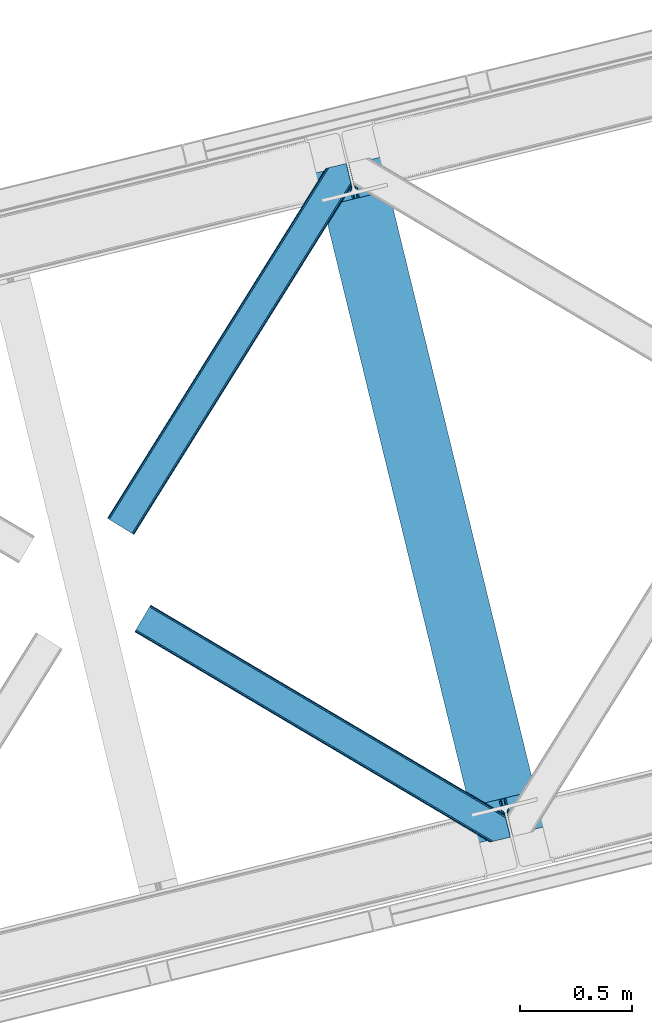
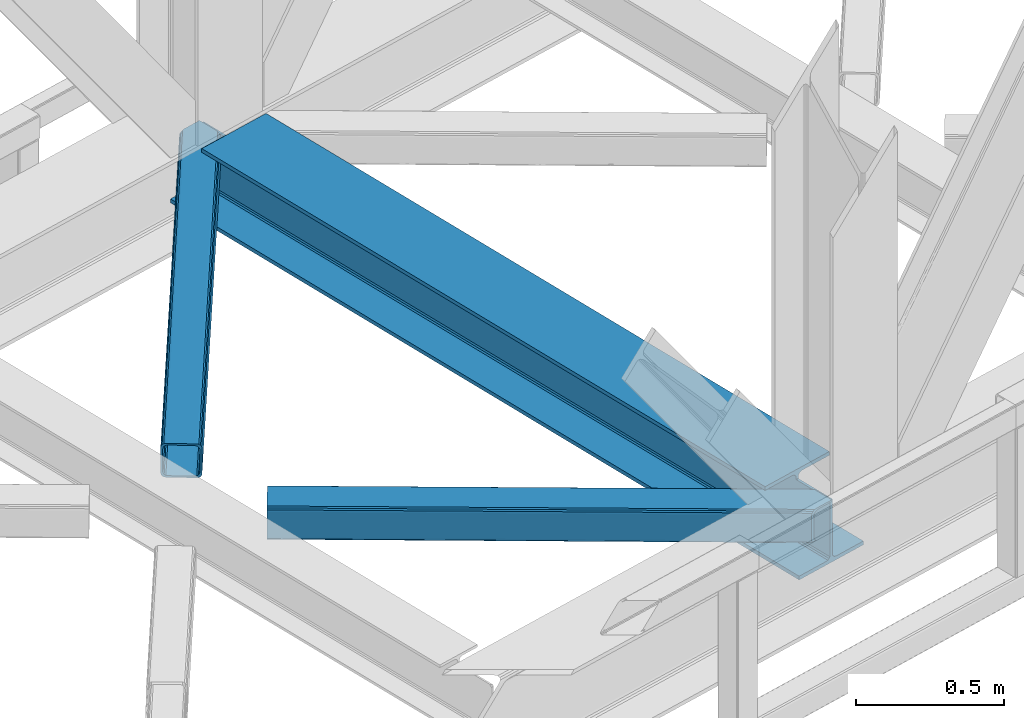
# One storey, part 66 of 93: 2 members, 1 beam.
"""IFC4 building model written with IfcOpenShell, lengths in millimetres."""

from ifc_helpers import new_model, entity, si_unit, converted_unit, derived_unit, direction, frame, origin, place, context, subcontext, project, spatial, triangles, polygons, material, type_object, element, save


model = new_model("IFC4")

# Units and contexts
model_context = context("Model", 3, precision=0.01, world=origin(), true_north=direction((6.12303176911189e-17, 1.0)))
plan_context = context("Plan", 3, precision=0.01, world=origin(), true_north=direction((6.12303176911189e-17, 1.0)))
body_context = subcontext(model_context, "Body", "Model", "MODEL_VIEW")
ifc_project = project(units=[si_unit("LENGTHUNIT", "METRE", prefix="MILLI"), si_unit("AREAUNIT", "SQUARE_METRE"), si_unit("VOLUMEUNIT", "CUBIC_METRE"), converted_unit("PLANEANGLEUNIT", "DEGREE", entity("IfcRatioMeasure", 0.0174532925199433), si_unit("PLANEANGLEUNIT", "RADIAN"), dimensions=[0, 0, 0, 0, 0, 0, 0]), si_unit("MASSUNIT", "GRAM", prefix="KILO"), derived_unit("MASSDENSITYUNIT", [(si_unit("MASSUNIT", "GRAM", prefix="KILO"), 1), (si_unit("LENGTHUNIT", "METRE"), -3)]), derived_unit("MOMENTOFINERTIAUNIT", [(si_unit("LENGTHUNIT", "METRE"), 4)]), si_unit("TIMEUNIT", "SECOND"), si_unit("FREQUENCYUNIT", "HERTZ"), si_unit("THERMODYNAMICTEMPERATUREUNIT", "DEGREE_CELSIUS"), derived_unit("THERMALTRANSMITTANCEUNIT", [(si_unit("MASSUNIT", "GRAM", prefix="KILO"), 1), (si_unit("THERMODYNAMICTEMPERATUREUNIT", "KELVIN"), -1), (si_unit("TIMEUNIT", "SECOND"), -3)]), derived_unit("VOLUMETRICFLOWRATEUNIT", [(si_unit("LENGTHUNIT", "METRE"), 3), (si_unit("TIMEUNIT", "SECOND"), -1)]), derived_unit("MASSFLOWRATEUNIT", [(si_unit("MASSUNIT", "GRAM", prefix="KILO"), 1), (si_unit("TIMEUNIT", "SECOND"), -1)]), derived_unit("ROTATIONALFREQUENCYUNIT", [(si_unit("TIMEUNIT", "SECOND"), -1)]), si_unit("ELECTRICCURRENTUNIT", "AMPERE"), si_unit("ELECTRICVOLTAGEUNIT", "VOLT"), si_unit("POWERUNIT", "WATT"), si_unit("FORCEUNIT", "NEWTON", prefix="KILO"), si_unit("ILLUMINANCEUNIT", "LUX"), si_unit("LUMINOUSFLUXUNIT", "LUMEN"), si_unit("LUMINOUSINTENSITYUNIT", "CANDELA"), derived_unit("USERDEFINED", [(si_unit("MASSUNIT", "GRAM", prefix="KILO"), -1), (si_unit("LENGTHUNIT", "METRE"), -2), (si_unit("TIMEUNIT", "SECOND"), 3), (si_unit("LUMINOUSFLUXUNIT", "LUMEN"), 1)]), derived_unit("LINEARVELOCITYUNIT", [(si_unit("LENGTHUNIT", "METRE"), 1), (si_unit("TIMEUNIT", "SECOND"), -1)]), si_unit("PRESSUREUNIT", "PASCAL"), derived_unit("USERDEFINED", [(si_unit("LENGTHUNIT", "METRE"), -2), (si_unit("MASSUNIT", "GRAM", prefix="KILO"), 1), (si_unit("TIMEUNIT", "SECOND"), -2)]), derived_unit("LINEARFORCEUNIT", [(si_unit("MASSUNIT", "GRAM", prefix="KILO"), 1), (si_unit("LENGTHUNIT", "METRE"), 1), (si_unit("TIMEUNIT", "SECOND"), -2), (si_unit("LENGTHUNIT", "METRE"), -1)]), derived_unit("PLANARFORCEUNIT", [(si_unit("MASSUNIT", "GRAM", prefix="KILO"), 1), (si_unit("LENGTHUNIT", "METRE"), 1), (si_unit("TIMEUNIT", "SECOND"), -2), (si_unit("LENGTHUNIT", "METRE"), -2)])], contexts=[model_context, plan_context])

# Site, building, storey
site_placement = place(None, origin())
site = spatial("IfcSite", under=ifc_project, at=site_placement, CompositionType="ELEMENT")
building_placement = place(site_placement, origin())
building = spatial("IfcBuilding", under=site, at=building_placement, CompositionType="ELEMENT")
storey_placement = place(building_placement, frame((0.0, 0.0, 15900.0)))
storey = spatial("IfcBuildingStorey", under=building, at=storey_placement, CompositionType="ELEMENT", Elevation=15900.0)

# Beam
ifc_material = material(Name="Metal painted (White)")
beam_type = type_object("IfcBeamType", PredefinedType="BEAM")
beam_placement = place(storey_placement, frame((-18024.6116349048, 13401.2394300083, 3385.0)))
element("IfcBeam", 1, at=beam_placement, inside=storey, type_object=beam_type, material=ifc_material, ObjectType="Steel Beam", PredefinedType="BEAM", context=body_context, shape_type="Tessellation", body=[
    polygons([(1018.1664837833, 71.0478278971021, 15.4999999999986), (1018.1664837833, 71.0478278971021, 0.0), (291.465617442448, 3052.25531830422, 0.0), (291.465617442448, 3052.25531830422, 15.4999999999986), (894.779372399336, 40.9709140873291, 15.4999999999986), (168.078506058485, 3022.17840449444, 15.4999999999986), (888.087028625368, 39.3395844888221, 16.8701684148006), (161.38616228452, 3020.54707489593, 16.8701684148006), (882.413533524757, 37.956610033654, 20.7720779386413), (155.712667183904, 3019.16410044077, 20.7720779386413), (878.622625296178, 37.0325360459162, 26.6116982174316), (151.921758955327, 3018.24002645303, 26.6116982174316), (877.291435352781, 36.7080444135007, 33.500000000001), (150.59056901193, 3017.91553482062, 33.500000000001), (140.875048430516, 3015.54727389071, 33.500000000001), (140.875048430516, 3015.54727389071, 259.000000000002), (150.59056901193, 3017.91553482062, 259.000000000002), (8.66293703438714e-12, 2981.20749040711, 0.0), (6.49720277579036e-12, 2981.20749040711, 15.4999999999986), (123.38711138397, 3011.28440421689, 15.4999999999986), (130.079455157935, 3012.91573381539, 16.8701684147963), (135.752950258553, 3014.29870827056, 20.7720779386413), (139.543858487119, 3015.22278225829, 26.6116982174294), (877.291435352781, 36.7080444135007, 259.000000000002), (867.575914771367, 34.3397834835992, 259.000000000002), (867.575914771369, 34.3397834835992, 33.500000000001), (866.24472482797, 34.0152918511837, 26.6116982174294), (862.453816599404, 33.0912178634546, 20.7720779386413), (856.780321498788, 31.7082434082822, 16.8701684147963), (850.087977724821, 30.0769138097752, 15.4999999999986), (726.700866340857, 0.0, 15.4999999999986), (726.700866340857, 0.0, 0.0), (838.124523615912, 197.385937999183, 259.069791973884), (186.469722099971, 2870.72539801219, 259.000000000002), (186.693115201822, 2869.80895360721, 259.61730333112), (186.705504045448, 2869.75812937344, 266.500003008253), (837.979344808145, 197.981416001708, 266.500002998871), (837.979694928899, 197.979979696973, 260.000004007589), (828.499586345876, 194.645865944434, 259.006343171919), (828.276216326111, 195.562317481914, 259.61730333112), (828.263827482484, 195.613141715689, 266.500003008253), (176.989986719784, 2867.38985508742, 266.500002998871), (176.989636599034, 2867.39129139215, 260.000004007589), (176.844830940692, 2867.98534020594, 259.07612046749), (176.754201518561, 2868.35713708228, 259.000000000002), (839.310832678068, 198.304685446393, 273.388305639783), (843.10110926677, 199.231350618306, 279.227924098781), (848.774180214294, 200.616065081981, 283.12983240061), (855.46637189544, 202.248018612798, 284.500000377228), (978.853400583278, 232.325271667905, 284.500000138971), (978.851730776626, 232.332121736639, 299.999995328161), (687.386308679356, 161.283492472598, 299.999995890962), (687.387978486005, 161.276642403863, 284.500000701776), (810.775007173849, 191.353895458974, 284.500000463519), (817.467494070001, 192.984637925557, 283.129832461069), (823.141405718761, 194.365903570083, 279.227924137322), (826.93294050574, 195.287407219375, 273.388305663684), (175.658498849859, 2867.06658564273, 273.388305639788), (171.868222261176, 2866.13992047082, 279.227924098781), (166.195151313642, 2864.75520600715, 283.129832400619), (159.502959632499, 2863.12325247633, 284.500000377228), (36.115930944662, 2833.04599942122, 284.500000138971), (36.1176007513137, 2833.03914935249, 299.999995328161), (327.583022848584, 2904.08777861653, 299.999995890962), (327.581353041935, 2904.09462868526, 284.500000701776), (204.19432435409, 2874.01737563015, 284.500000463519), (197.501837457939, 2872.38663316357, 283.12983246106), (191.827925809187, 2871.00536751904, 279.227924137322), (188.036391022187, 2870.08386386975, 273.388305663684)], [[[1, 2, 3, 4]], [[5, 1, 4, 6]], [[7, 5, 6, 8]], [[9, 7, 8, 10]], [[11, 9, 10, 12]], [[13, 11, 12, 14]], [[15, 16, 17, 14, 12, 10, 8, 6, 4, 3, 18, 19, 20, 21, 22, 23]], [[13, 24, 25, 26, 27, 28, 29, 30, 31, 32, 2, 1, 5, 7, 9, 11]], [[2, 32, 18, 3]], [[32, 31, 19, 18]], [[31, 30, 20, 19]], [[27, 26, 15, 23]], [[28, 27, 23, 22]], [[29, 28, 22, 21]], [[30, 29, 21, 20]], [[33, 24, 13, 14, 17, 34, 35, 36, 37, 38]], [[25, 39, 40, 41, 42, 43, 44, 16, 15, 26]], [[39, 25, 24, 33]], [[45, 34, 17, 16]], [[41, 40, 38, 37, 46, 47, 48, 49, 50, 51, 52, 53, 54, 55, 56, 57]], [[42, 58, 59, 60, 61, 62, 63, 64, 65, 66, 67, 68, 69, 36, 35, 43]], [[46, 37, 36, 69]], [[47, 46, 69, 68]], [[48, 47, 68, 67]], [[49, 48, 67, 66]], [[50, 49, 66, 65]], [[51, 50, 65, 64]], [[52, 51, 64, 63]], [[53, 52, 63, 62]], [[54, 53, 62, 61]], [[55, 54, 61, 60]], [[56, 55, 60, 59]], [[57, 56, 59, 58]], [[41, 57, 58, 42]]], closed=False),
])

# Members
member_type_1 = type_object("IfcMemberType", PredefinedType="BRACE")
member_1_placement = place(storey_placement, frame((-18949.8456481934, 14772.5982971191, 3510.00011901855)))
element("IfcMember", 2, at=member_1_placement, inside=storey, type_object=member_type_1, ObjectType="Steel Horizontal Brace", PredefinedType="BRACE", context=body_context, shape_type="Tessellation", body=[
    triangles([(933.016305541994, 1535.69114685059, 0.0), (967.77581176758, 1393.09054870606, 0.0), (14.8444427490249, 64.8692962646492, 0.0), (103.913424682618, 9.26687622070313, 0.0), (928.799121093751, 1552.99009094238, 5.49966430664063), (928.938647460938, 1552.41570739746, 5.20782165527635), (930.798999023438, 1544.78594055176, 1.33247680664135), (971.99299621582, 1375.79160461426, 5.49966430664063), (971.852307128906, 1376.36715087891, 5.20782165527635), (969.993118286133, 1383.99575500488, 1.33247680664135), (972.208099365234, 1375.53813171387, 5.85313110351854), (972.418551635743, 1375.28233337402, 6.20659790039281), (928.911904907229, 1553.56912536621, 5.74383544921875), (972.720858764649, 1375.53696899414, 6.35310058594041), (929.027014160158, 1554.17606506348, 5.9996337890625), (973.022003173828, 1375.79160461426, 6.49960327148438), (929.142123413087, 1554.78300476074, 6.25659484863354), (929.250256347656, 1555.36203918457, 6.49960327148438), (4.34740905761646, 71.4223846435561, 5.12526855468968), (1.13016357422021, 73.4315643310547, 10.8028289794929), (973.355703735353, 1630.84231567383, 10.8028289794929), (976.91130065918, 1631.70854187012, 6.49960327148438), (9.16455688476708, 68.4167541503921, 1.33247680664135), (971.503491210937, 1630.3900177002, 17.5000946044929), (0.0, 74.1373352050796, 17.5000946044929), (1081.09680175781, 1548.91592102051, 6.49960327148438), (1056.20297241211, 1651.03759460449, 6.49960327148438), (971.503491210937, 1630.3900177002, 122.500662231447), (0.0, 74.1373352050796, 122.500662231447), (973.355703735353, 1630.84231567383, 129.197927856447), (1.13016357422021, 73.4315643310547, 129.197927856447), (978.633288574219, 1632.12828369141, 134.874325561526), (4.34740905761646, 71.4223846435561, 134.874325561526), (986.526992797852, 1634.05258483887, 138.667117309571), (9.16455688476708, 68.4167541503921, 138.667117309571), (995.835726928712, 1636.32221374512, 139.999594116212), (14.8444427490249, 64.8692962646492, 139.999594116212), (118.757867431643, 0.0, 17.5000946044929), (117.62886657715, 0.705770874024893, 10.8028289794929), (1085.13725280762, 1551.24949951172, 10.9783996582046), (1087.41153259277, 1552.56337280274, 13.5003387451179), (109.594473266603, 5.7205810546875, 1.33247680664135), (114.410458374023, 2.71495056152344, 5.12526855468968), (1087.56501159668, 1551.93434143066, 17.5000946044929), (1081.77234191895, 1575.70149536133, 139.999594116212), (1063.00372009277, 1652.69447021484, 139.999594116212), (103.913424682618, 9.26687622070313, 139.999594116212), (1083.9896484375, 1566.60553894043, 138.667117309571), (109.594473266603, 5.7205810546875, 138.667117309571), (1085.86860351562, 1558.8955444336, 134.874325561526), (114.410458374023, 2.71495056152344, 134.874325561526), (1087.12434082031, 1553.7435333252, 129.197927856447), (117.62886657715, 0.705770874024893, 129.197927856447), (1087.56501159668, 1551.93434143066, 122.500662231447), (118.757867431643, 0.0, 122.500662231447), (1082.5362487793, 1566.77297058106, 12.1260040283232), (1083.96058044434, 1566.72297363281, 13.5003387451179), (1077.84700012207, 1569.98440246582, 8.3320495605476), (1074.64603271485, 1577.50138549805, 6.99957275390625), (1056.69131469727, 1651.1561920166, 6.99957275390625), (1005.56885375977, 1638.69416198731, 6.99957275390625), (20.7789642333992, 61.1625457763676, 6.99957275390625), (97.9742523193381, 12.9736267089847, 6.99957275390625), (108.471286010743, 6.42053833007958, 12.1260040283232), (111.689694213866, 4.41252136230469, 17.8035644531265), (1084.80704040527, 1563.24992980957, 17.8035644531265), (103.65530090332, 9.42733154296911, 8.3320495605476), (1085.24771118164, 1561.44073791504, 24.4996673583992), (112.818695068359, 3.70675048828161, 24.4996673583992), (983.088830566408, 1633.21426391602, 17.8035644531265), (981.235455322265, 1632.76312866211, 24.4996673583992), (7.06468505859448, 69.7236511230476, 17.8035644531265), (5.93568420410156, 70.4294219970707, 24.4996673583992), (988.366415405275, 1634.50139465332, 12.1260040283232), (10.283093261718, 67.7144714355472, 12.1260040283232), (996.260119628907, 1636.42569580078, 8.3320495605476), (15.0990783691414, 64.7088409423832, 8.3320495605476), (981.235455322265, 1632.76312866211, 115.501089477541), (5.93568420410156, 70.4294219970707, 115.501089477541), (996.260119628907, 1636.42569580078, 131.667544555665), (1005.56885375977, 1638.69416198731, 133.000021362306), (1063.00372009277, 1652.69447021484, 133.000021362306), (988.366415405275, 1634.50139465332, 127.87475280762), (983.088830566408, 1633.21426391602, 122.196029663086), (20.7789642333992, 61.1625457763676, 133.000021362306), (15.0990783691414, 64.7088409423832, 131.667544555665), (10.283093261718, 67.7144714355472, 127.87475280762), (7.06468505859448, 69.7236511230476, 122.196029663086), (108.471286010743, 6.42053833007958, 127.87475280762), (111.689694213866, 4.41252136230469, 122.196029663086), (112.818695068359, 3.70675048828161, 115.501089477541), (97.9742523193381, 12.9736267089847, 133.000021362306), (103.65530090332, 9.42733154296911, 131.667544555665), (1085.24771118164, 1561.44073791504, 115.501089477541), (1084.80704040527, 1563.24992980957, 122.196029663086), (1083.55130310059, 1568.40194091797, 127.87475280762), (1081.67118530273, 1576.11309814453, 131.667544555665), (1079.45504150391, 1585.2078918457, 133.000021362306)], [[1, 2, 3], [4, 3, 2], [1, 5, 2], [6, 5, 1], [1, 7, 6], [2, 5, 8], [8, 9, 2], [10, 2, 9], [11, 8, 5], [12, 11, 13], [14, 12, 15], [16, 14, 17], [17, 18, 16], [15, 17, 14], [13, 15, 12], [5, 13, 11], [17, 19, 18], [19, 17, 15], [13, 19, 15], [19, 13, 5], [5, 6, 19], [20, 21, 18], [18, 19, 20], [21, 22, 18], [19, 6, 7], [7, 1, 23], [3, 23, 1], [7, 23, 19], [24, 21, 20], [20, 25, 24], [18, 26, 16], [26, 18, 22], [27, 26, 22], [28, 24, 29], [25, 29, 24], [30, 28, 31], [29, 31, 28], [32, 30, 33], [31, 33, 30], [34, 32, 35], [33, 35, 32], [36, 34, 37], [35, 37, 34], [38, 39, 40], [40, 41, 38], [42, 10, 9], [39, 12, 16], [16, 40, 39], [16, 26, 40], [9, 39, 43], [9, 12, 39], [9, 43, 42], [2, 10, 4], [42, 4, 10], [41, 44, 38], [45, 36, 37], [36, 45, 46], [37, 47, 45], [48, 45, 47], [47, 49, 48], [50, 48, 49], [49, 51, 50], [52, 50, 51], [51, 53, 52], [54, 52, 53], [53, 55, 54], [44, 54, 38], [55, 38, 54], [56, 40, 26], [41, 40, 56], [56, 57, 41], [58, 26, 59], [26, 58, 56], [60, 59, 26], [59, 61, 62], [61, 59, 60], [62, 63, 59], [64, 65, 66], [66, 57, 64], [58, 59, 63], [63, 67, 58], [56, 58, 67], [67, 64, 56], [57, 56, 64], [68, 66, 65], [65, 69, 68], [70, 71, 72], [73, 72, 71], [74, 70, 75], [72, 75, 70], [76, 74, 77], [75, 77, 74], [61, 76, 62], [77, 62, 76], [71, 78, 79], [79, 73, 71], [34, 36, 80], [46, 81, 36], [81, 46, 82], [81, 80, 36], [83, 34, 80], [83, 32, 34], [32, 84, 30], [84, 32, 83], [28, 84, 78], [84, 28, 30], [61, 22, 76], [70, 74, 22], [74, 76, 22], [61, 60, 22], [71, 70, 24], [21, 24, 70], [28, 71, 24], [71, 28, 78], [70, 22, 21], [80, 81, 85], [85, 86, 80], [83, 80, 86], [86, 87, 83], [84, 83, 87], [87, 88, 84], [78, 84, 88], [88, 79, 78], [53, 89, 90], [91, 38, 55], [53, 90, 55], [53, 51, 89], [90, 91, 55], [89, 51, 49], [92, 47, 37], [47, 93, 49], [93, 47, 92], [93, 89, 49], [39, 64, 43], [69, 38, 91], [38, 65, 39], [65, 38, 69], [39, 65, 64], [4, 63, 3], [42, 43, 64], [64, 67, 42], [67, 63, 4], [4, 42, 67], [87, 35, 33], [37, 85, 92], [37, 86, 85], [86, 37, 35], [87, 86, 35], [79, 29, 25], [31, 88, 87], [33, 31, 87], [88, 31, 29], [79, 88, 29], [23, 75, 19], [3, 63, 62], [62, 77, 3], [77, 75, 23], [23, 3, 77], [20, 19, 75], [25, 73, 79], [72, 25, 20], [25, 72, 73], [72, 20, 75], [66, 41, 57], [54, 44, 68], [44, 66, 68], [68, 94, 54], [44, 41, 66], [95, 54, 94], [52, 54, 95], [50, 95, 96], [95, 50, 52], [96, 48, 50], [97, 48, 96], [97, 98, 45], [97, 45, 48], [98, 46, 45], [98, 82, 46], [81, 98, 85], [81, 82, 98], [92, 85, 98], [95, 94, 90], [91, 90, 94], [96, 95, 89], [90, 89, 95], [97, 96, 93], [89, 93, 96], [98, 97, 92], [93, 92, 97], [94, 68, 69], [69, 91, 94]]),
])
member_type_2 = type_object("IfcMemberType", PredefinedType="BRACE")
member_2_placement = place(storey_placement, frame((-18828.0891265869, 13404.2934448242, 3510.00011901855)))
element("IfcMember", 3, at=member_2_placement, inside=storey, type_object=member_type_2, ObjectType="Steel Horizontal Brace", PredefinedType="BRACE", context=body_context, shape_type="Tessellation", body=[
    triangles([(1468.20108032227, 208.966314697265, 0.0), (1502.96174926758, 66.3657165527347, 0.0), (8.9145721435525, 950.879168701171, 0.0), (62.4054931640603, 1041.23295593262, 0.0), (0.677865600584482, 936.96722717285, 10.8028289794929), (1582.93826293945, 0.542990112304324, 10.8679412841811), (1580.71049194336, 0.0, 17.5000946044929), (1509.32066345215, 44.5019348144524, 9.52034912109593), (2.6114685058601, 940.232144165038, 5.12526855468968), (1507.05801086426, 49.5597656249993, 5.12526855468968), (1507.93353881836, 45.9669616699211, 8.52041015625218), (1508.98463745117, 44.856564331054, 9.27850341796875), (1508.63000793457, 45.2344482421868, 9.02037963867406), (1508.26956481934, 45.6123321533196, 8.76225585937573), (1583.38939819336, 0.653448486327761, 9.52034912109593), (1505.17905578613, 57.2709228515614, 1.33247680664135), (5.50315246581886, 945.116729736328, 1.33247680664135), (0.0, 935.820785522461, 17.5000946044929), (1580.71049194336, 0.0, 122.500662231447), (0.0, 935.820785522461, 122.500662231447), (1595.73399353027, 3.66256713867188, 138.667117309571), (1605.04272766113, 5.93103332519422, 139.999594116212), (8.9145721435525, 950.879168701171, 139.999594116212), (5.50315246581886, 945.116729736328, 138.667117309571), (1587.84028930664, 1.73826599121094, 134.874325561526), (2.6114685058601, 940.232144165038, 134.874325561526), (1582.56270446777, 0.451135253906614, 129.197927856447), (0.677865600584482, 936.96722717285, 129.197927856447), (1503.00593261719, 66.183169555663, 8.52041015625218), (1503.36637573242, 65.041378784179, 8.90294494629052), (1503.85704345703, 64.3216552734375, 9.10758361816625), (1504.35585021973, 63.5937927246086, 9.31571044922021), (1504.84186706543, 62.8729064941399, 9.52034912109593), (1602.19638977051, 5.23805236816406, 9.52034912109593), (9.07153930663844, 951.140780639647, 8.3320495605476), (1502.85361633301, 66.8075500488285, 8.42274169922166), (6.1786926269524, 946.255032348632, 12.1260040283232), (1597.57341613769, 4.11021423339844, 12.1260040283232), (1500.64444885254, 75.8721130371086, 6.99957275390625), (12.4817962646484, 956.903219604492, 6.99957275390625), (1592.29583129883, 2.82424621581958, 17.8035644531265), (4.24625244140407, 942.991278076172, 17.8035644531265), (1590.44361877441, 2.37311096191297, 24.4996673583992), (3.56373596191406, 941.843673706055, 24.4996673583992), (1470.5183807373, 199.458755493164, 6.99957275390625), (58.838269042968, 1035.2089050293, 6.99957275390625), (1463.22929077148, 229.365069580077, 8.52041015625218), (1468.15689697265, 209.14769897461, 8.52041015625218), (1464.10481872558, 225.771102905273, 5.12526855468968), (1468.30921325683, 208.524481201172, 8.42274169922166), (1465.98377380371, 218.061108398437, 1.33247680664135), (1590.44361877441, 2.37311096191297, 115.501089477541), (3.56373596191406, 941.843673706055, 115.501089477541), (1592.29583129883, 2.82424621581958, 122.196029663086), (4.24625244140407, 942.991278076172, 122.196029663086), (1597.57341613769, 4.11021423339844, 127.87475280762), (6.1786926269524, 946.255032348632, 127.87475280762), (1605.46712036133, 6.03451538085938, 131.667544555665), (9.07153930663844, 951.140780639647, 131.667544555665), (1614.77585449219, 8.30414428710901, 133.000021362306), (12.4817962646484, 956.903219604492, 133.000021362306), (1672.21072082519, 22.3044525146488, 139.999594116212), (1672.21072082519, 22.3044525146488, 133.000021362306), (1653.44326171875, 99.2985900878903, 139.999594116212), (62.4054931640603, 1041.23295593262, 139.999594116212), (1655.76056213379, 89.7910308837891, 133.000021362306), (58.838269042968, 1035.2089050293, 133.000021362306), (1648.09126281738, 121.255389404296, 129.197927856447), (1647.64942932129, 123.064581298828, 122.500662231447), (70.642199707032, 1055.14489746094, 129.197927856447), (71.3200653076165, 1056.29133911133, 122.500662231447), (1649.34700012207, 116.103378295898, 134.874325561526), (68.7097595214836, 1051.88114318848, 134.874325561526), (1651.2259552002, 108.393383789062, 138.667117309571), (65.8169128417976, 1046.99539489746, 138.667117309571), (1647.64942932129, 123.064581298828, 17.5000946044929), (71.3200653076165, 1056.29133911133, 17.5000946044929), (70.642199707032, 1055.14489746094, 10.8028289794929), (65.1425354003914, 1045.85709228516, 12.1260040283232), (67.074975585936, 1049.12200927734, 17.8035644531265), (67.7528411865242, 1050.26728820801, 24.4996673583992), (68.7097595214836, 1051.88114318848, 5.12526855468968), (65.8169128417976, 1046.99539489746, 1.33247680664135), (62.2496887207017, 1040.97134399414, 8.3320495605476), (65.1425354003914, 1045.85709228516, 127.87475280762), (67.7528411865242, 1050.26728820801, 115.501089477541), (67.074975585936, 1049.12200927734, 122.196029663086), (62.2496887207017, 1040.97134399414, 131.667544555665), (1649.96672973633, 113.558184814452, 24.4996673583992), (1649.96672973633, 113.558184814452, 115.501089477541), (1653.54325561523, 98.8869873046879, 131.667544555665), (1651.66430053711, 106.596981811523, 127.87475280762), (1650.40856323242, 111.748992919922, 122.196029663086), (1650.49692993164, 111.385061645507, 17.8686767578147), (1650.60390014649, 110.943228149414, 16.5199218750022), (1647.6587310791, 123.027374267578, 16.5199218750022), (1641.3730682373, 124.97144165039, 10.8702667236357), (1463.4490447998, 229.701095581055, 9.22734375000073), (1463.34091186523, 229.533663940429, 8.87387695312646), (1464.24783325195, 229.405764770507, 9.52034912109593), (1639.8673461914, 125.435366821288, 9.52034912109593), (1646.38206481934, 109.728186035156, 12.1260040283232), (1468.72662963867, 211.034793090819, 9.52034912109593), (1644.34614257812, 107.0643951416, 9.52034912109593)], [[1, 2, 3], [3, 4, 1], [5, 6, 7], [6, 5, 8], [5, 9, 10], [10, 11, 5], [12, 5, 13], [12, 8, 5], [5, 14, 13], [5, 11, 14], [8, 15, 6], [16, 10, 9], [9, 17, 16], [2, 16, 17], [17, 3, 2], [7, 18, 5], [7, 19, 20], [20, 18, 7], [21, 22, 23], [23, 24, 21], [25, 21, 24], [24, 26, 25], [27, 25, 26], [26, 28, 27], [19, 27, 28], [28, 20, 19], [11, 29, 30], [14, 30, 31], [13, 31, 32], [12, 32, 33], [33, 8, 12], [32, 12, 13], [31, 13, 14], [30, 14, 11], [34, 15, 33], [8, 33, 15], [35, 30, 29], [32, 35, 33], [35, 32, 31], [30, 35, 31], [29, 36, 35], [37, 38, 33], [33, 35, 37], [38, 34, 33], [35, 36, 39], [39, 40, 35], [41, 38, 37], [37, 42, 41], [43, 41, 42], [42, 44, 43], [39, 45, 40], [46, 40, 45], [1, 45, 39], [47, 48, 49], [48, 50, 1], [45, 1, 50], [48, 51, 49], [48, 1, 51], [2, 1, 39], [2, 39, 36], [29, 2, 36], [11, 10, 29], [29, 16, 2], [29, 10, 16], [52, 43, 44], [44, 53, 52], [54, 52, 55], [53, 55, 52], [56, 54, 57], [55, 57, 54], [58, 56, 59], [57, 59, 56], [60, 58, 61], [59, 61, 58], [56, 58, 21], [25, 56, 21], [25, 27, 54], [56, 25, 54], [54, 27, 19], [58, 22, 21], [62, 60, 63], [62, 22, 60], [58, 60, 22], [54, 19, 52], [43, 7, 41], [19, 43, 52], [7, 6, 41], [19, 7, 43], [15, 41, 6], [38, 41, 15], [34, 38, 15], [22, 64, 23], [22, 62, 64], [65, 23, 64], [66, 60, 61], [60, 66, 63], [61, 67, 66], [68, 69, 70], [71, 70, 69], [72, 68, 73], [70, 73, 68], [74, 72, 75], [73, 75, 72], [64, 74, 65], [75, 65, 74], [69, 76, 77], [77, 71, 69], [78, 79, 80], [81, 71, 77], [78, 80, 77], [78, 82, 79], [80, 81, 77], [79, 82, 83], [46, 4, 3], [4, 84, 83], [84, 4, 46], [84, 79, 83], [70, 85, 73], [86, 71, 81], [71, 87, 70], [87, 71, 86], [70, 87, 85], [65, 67, 23], [75, 73, 85], [85, 88, 75], [88, 67, 65], [65, 75, 88], [37, 17, 9], [3, 40, 46], [3, 35, 40], [35, 3, 17], [37, 35, 17], [44, 18, 20], [5, 42, 37], [9, 5, 37], [42, 5, 18], [44, 42, 18], [24, 57, 26], [23, 67, 61], [61, 59, 23], [59, 57, 24], [24, 23, 59], [28, 26, 57], [20, 53, 44], [55, 20, 28], [20, 55, 53], [55, 28, 57], [89, 90, 81], [86, 81, 90], [91, 66, 67], [67, 88, 91], [92, 91, 88], [88, 85, 92], [93, 92, 85], [85, 87, 93], [90, 93, 87], [87, 86, 90], [92, 72, 74], [66, 91, 64], [91, 92, 74], [94, 95, 96], [63, 66, 62], [64, 62, 66], [91, 74, 64], [94, 76, 89], [69, 90, 89], [89, 76, 69], [94, 96, 76], [69, 93, 90], [93, 72, 92], [72, 93, 68], [69, 68, 93], [77, 76, 97], [76, 96, 97], [98, 99, 82], [47, 82, 99], [47, 49, 82], [78, 97, 100], [100, 82, 78], [100, 98, 82], [97, 101, 100], [51, 1, 4], [4, 83, 51], [49, 51, 83], [83, 82, 49], [97, 78, 77], [80, 79, 102], [102, 95, 80], [80, 94, 89], [46, 45, 50], [103, 102, 79], [103, 104, 102], [50, 79, 84], [50, 103, 79], [50, 84, 46], [89, 81, 80], [95, 94, 80], [96, 102, 97], [102, 96, 95], [102, 101, 97], [102, 104, 101], [101, 104, 103], [103, 100, 101]]),
])

save(model, "model.ifc")
